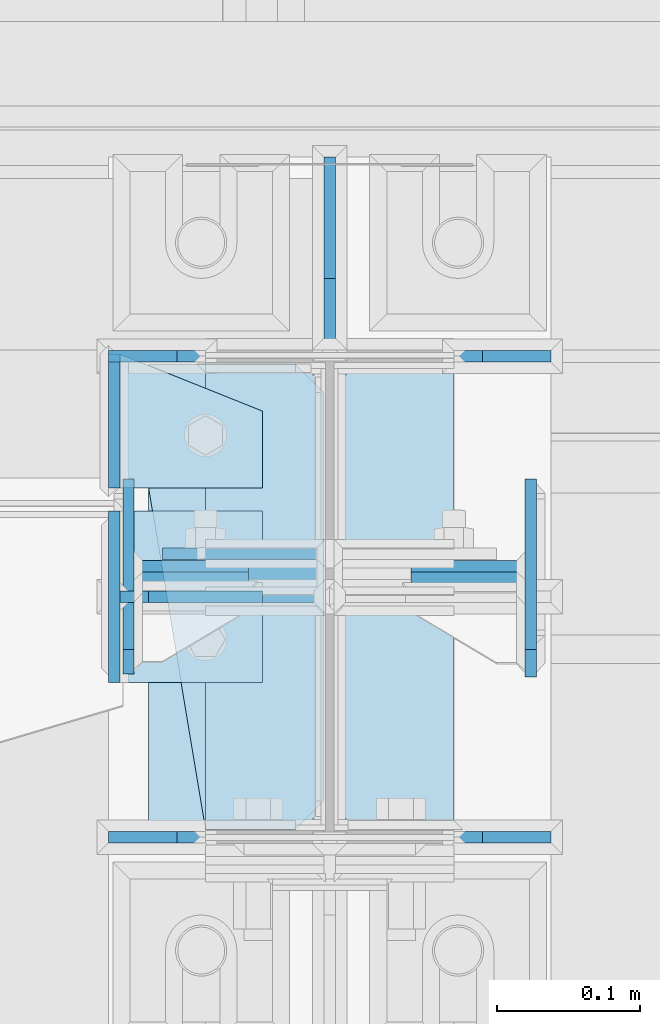
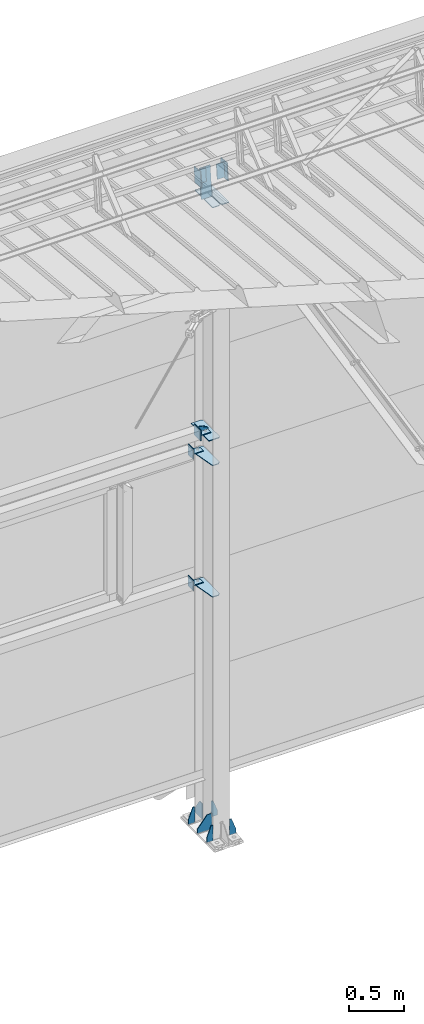
# One storey, part 165 of 709: 23 plates, 6 elements without a shape of their own.
"""IFC4 building model written with IfcOpenShell, lengths in millimetres."""

from ifc_helpers import new_model, si_unit, direction, frame, origin_with_axes, place, context, subcontext, project, spatial, line, indexed_curve, outline, extrude, material, element, aggregate, save


model = new_model("IFC4")

# Units and contexts
model_context = context("Model", 3, precision=0.2, world=origin_with_axes(), true_north=direction((0.0, 1.0)))
body_context = subcontext(model_context, "Body", "Model", "MODEL_VIEW")
ifc_project = project(units=[si_unit("LENGTHUNIT", "METRE", prefix="MILLI"), si_unit("AREAUNIT", "SQUARE_METRE"), si_unit("VOLUMEUNIT", "CUBIC_METRE"), si_unit("MASSUNIT", "GRAM", prefix="KILO"), si_unit("TIMEUNIT", "SECOND"), si_unit("PLANEANGLEUNIT", "RADIAN"), si_unit("SOLIDANGLEUNIT", "STERADIAN"), si_unit("THERMODYNAMICTEMPERATUREUNIT", "DEGREE_CELSIUS"), si_unit("LUMINOUSINTENSITYUNIT", "LUMEN")], contexts=[model_context])

# Site, building, storey
site_placement = place(None, origin_with_axes())
site = spatial("IfcSite", under=ifc_project, at=site_placement, CompositionType="ELEMENT")
building_placement = place(site_placement, origin_with_axes())
building = spatial("IfcBuilding", under=site, at=building_placement, Name="Undefined", CompositionType="ELEMENT")
storey_placement = place(building_placement, origin_with_axes())
storey = spatial("IfcBuildingStorey", under=building, at=storey_placement, Name="Undefined", CompositionType="ELEMENT", Elevation=0.0)

# Assembly, plates
assembly_1_placement = place(storey_placement, frame((46000.0, 21827.0, -200.0), z_axis=(-1.0, 0.0, 0.0), x_axis=(0.0, 0.0, 1.0)))
assembly_1 = element("IfcElementAssembly", 1, at=assembly_1_placement, inside=storey)
ifc_material = material(Name="C355-6", Category="STEEL")
plate_1_placement = place(assembly_1_placement, frame((25.0, 168.5, -87.0), z_axis=(0.0, -1.0, 0.0), x_axis=(0.0, 0.0, -1.0)))
plate_1 = element("IfcPlate", 2, at=plate_1_placement, material=ifc_material, ObjectType="419", context=body_context, shape_type="SolidModel", body=[
    extrude(outline(indexed_curve([(0.0, 0.0), (68.0, 0.0), (68.0, 50.0), (20.0, 175.0), (0.0, 175.0)], segments=[line(1, 2, 3, 4, 5, 1)])), frame((0.0, 0.0, 4.0), z_axis=(0.0, 0.0, 1.0), x_axis=(1.0, 0.0, 0.0)), (0.0, 0.0, -1.0), 8.0),
])
plate_2_placement = place(assembly_1_placement, frame((25.0, 168.5, 87.0), z_axis=(0.0, 1.0, 0.0), x_axis=(0.0, 0.0, 1.0)))
plate_2 = element("IfcPlate", 3, at=plate_2_placement, material=ifc_material, ObjectType="419", context=body_context, shape_type="SolidModel", body=[
    extrude(outline(indexed_curve([(0.0, 0.0), (68.0, 0.0), (68.0, 50.0), (20.0, 175.0), (0.0, 175.0)], segments=[line(1, 2, 3, 4, 5, 1)])), frame((0.0, 0.0, 4.0), z_axis=(0.0, 0.0, 1.0), x_axis=(1.0, 0.0, 0.0)), (0.0, 0.0, -1.0), 8.0),
])
plate_3_placement = place(assembly_1_placement, frame((25.0, -168.5, -87.0), z_axis=(0.0, -1.0, 0.0), x_axis=(0.0, 0.0, -1.0)))
plate_3 = element("IfcPlate", 4, at=plate_3_placement, material=ifc_material, ObjectType="419", context=body_context, shape_type="SolidModel", body=[
    extrude(outline(indexed_curve([(0.0, 0.0), (68.0, 0.0), (68.0, 50.0), (20.0, 175.0), (0.0, 175.0)], segments=[line(1, 2, 3, 4, 5, 1)])), frame((0.0, 0.0, 4.0), z_axis=(0.0, 0.0, 1.0), x_axis=(1.0, 0.0, 0.0)), (0.0, 0.0, -1.0), 8.0),
])
plate_4_placement = place(assembly_1_placement, frame((25.0, -168.5, 87.0), z_axis=(0.0, 1.0, 0.0), x_axis=(0.0, 0.0, 1.0)))
plate_4 = element("IfcPlate", 5, at=plate_4_placement, material=ifc_material, ObjectType="419", context=body_context, shape_type="SolidModel", body=[
    extrude(outline(indexed_curve([(0.0, 0.0), (68.0, 0.0), (68.0, 50.0), (20.0, 175.0), (0.0, 175.0)], segments=[line(1, 2, 3, 4, 5, 1)])), frame((0.0, 0.0, 4.0), z_axis=(0.0, 0.0, 1.0), x_axis=(1.0, 0.0, 0.0)), (0.0, 0.0, -1.0), 8.0),
])
plate_5_placement = place(assembly_1_placement, frame((25.0, 0.0, 3.0), z_axis=(0.0, 1.0, 0.0), x_axis=(0.0, 0.0, 1.0)))
plate_5 = element("IfcPlate", 6, at=plate_5_placement, material=ifc_material, ObjectType="417", context=body_context, shape_type="SolidModel", body=[
    extrude(outline(indexed_curve([(0.0, 0.0), (152.0, 0.0), (152.0, 50.0), (50.0, 175.0), (0.0, 175.0)], segments=[line(1, 2, 3, 4, 5, 1)])), frame((0.0, 0.0, 4.0), z_axis=(0.0, 0.0, 1.0), x_axis=(1.0, 0.0, 0.0)), (0.0, 0.0, -1.0), 8.0),
])
plate_6_placement = place(assembly_1_placement, frame((25.0, 173.0, 0.0), z_axis=(0.0, 0.0, -1.0), x_axis=(0.0, 1.0, 0.0)))
plate_6 = element("IfcPlate", 7, at=plate_6_placement, material=ifc_material, ObjectType="418", context=body_context, shape_type="SolidModel", body=[
    extrude(outline(indexed_curve([(0.0, 0.0), (135.0, 0.0), (135.0, 50.0), (50.0, 175.0), (0.0, 175.0)], segments=[line(1, 2, 3, 4, 5, 1)])), frame((0.0, 0.0, 4.0), z_axis=(0.0, 0.0, 1.0), x_axis=(1.0, 0.0, 0.0)), (0.0, 0.0, -1.0), 8.0),
])
plate_7_placement = place(assembly_1_placement, frame((7097.93718, -163.0, -87.0), z_axis=(-1.0, 0.0, 0.0), x_axis=(0.0, 0.0, 1.0)))
plate_7 = element("IfcPlate", 8, at=plate_7_placement, material=ifc_material, ObjectType="461", context=body_context, shape_type="SolidModel", body=[
    extrude(outline(indexed_curve([(0.0, 0.0), (68.0, 0.0), (83.0, 15.0), (83.0, 311.0), (68.0, 326.0), (0.0, 326.0)], segments=[line(1, 2, 3, 4, 5, 6, 1)])), frame((0.0, 0.0, 4.0), z_axis=(0.0, 0.0, 1.0), x_axis=(1.0, 0.0, 0.0)), (0.0, 0.0, -1.0), 8.0),
])
plate_8_placement = place(assembly_1_placement, frame((7097.93718, 163.0, 87.0), z_axis=(-1.0, 0.0, 0.0), x_axis=(0.0, 0.0, -1.0)))
plate_8 = element("IfcPlate", 9, at=plate_8_placement, material=ifc_material, ObjectType="461", context=body_context, shape_type="SolidModel", body=[
    extrude(outline(indexed_curve([(0.0, 0.0), (68.0, 0.0), (83.0, 15.0), (83.0, 311.0), (68.0, 326.0), (0.0, 326.0)], segments=[line(1, 2, 3, 4, 5, 6, 1)])), frame((0.0, 0.0, 4.0), z_axis=(0.0, 0.0, 1.0), x_axis=(1.0, 0.0, 0.0)), (0.0, 0.0, -1.0), 8.0),
])
plate_9_placement = place(assembly_1_placement, frame((2742.0, 163.0, 4.0), z_axis=(1.0, 0.0, 0.0), x_axis=(0.0, 0.0, 1.0)))
plate_9 = element("IfcPlate", 10, at=plate_9_placement, material=ifc_material, ObjectType="543", context=body_context, shape_type="SolidModel", body=[
    extrude(outline(indexed_curve([(0.0, 20.0), (20.0, 0.0), (123.0, 0.0), (123.0, 86.0), (83.0, 326.0), (20.0, 326.0), (0.0, 306.0)], segments=[line(1, 2, 3, 4, 5, 6, 7, 1)])), frame((0.0, 0.0, 4.0), z_axis=(0.0, 0.0, 1.0), x_axis=(1.0, 0.0, 0.0)), (0.0, 0.0, -1.0), 8.0),
])
plate_10_placement = place(assembly_1_placement, frame((4212.0, 163.0, 4.0), z_axis=(1.0, 0.0, 0.0), x_axis=(0.0, 0.0, 1.0)))
plate_10 = element("IfcPlate", 11, at=plate_10_placement, material=ifc_material, ObjectType="543", context=body_context, shape_type="SolidModel", body=[
    extrude(outline(indexed_curve([(0.0, 20.0), (20.0, 0.0), (123.0, 0.0), (123.0, 86.0), (83.0, 326.0), (20.0, 326.0), (0.0, 306.0)], segments=[line(1, 2, 3, 4, 5, 6, 7, 1)])), frame((0.0, 0.0, 4.0), z_axis=(0.0, 0.0, 1.0), x_axis=(1.0, 0.0, 0.0)), (0.0, 0.0, -1.0), 8.0),
])
plate_11_placement = place(assembly_1_placement, frame((4502.0, 163.0, 127.0), z_axis=(-1.0, 0.0, 0.0), x_axis=(0.0, 0.0, -1.0)))
plate_11 = element("IfcPlate", 12, at=plate_11_placement, material=ifc_material, ObjectType="547", context=body_context, shape_type="SolidModel", body=[
    extrude(outline(indexed_curve([(0.0, 0.0), (108.0, 0.0), (123.0, 15.0), (123.0, 311.0), (108.0, 326.0), (0.0, 326.0)], segments=[line(1, 2, 3, 4, 5, 6, 1)])), frame((0.0, 0.0, 4.0), z_axis=(0.0, 0.0, 1.0), x_axis=(1.0, 0.0, 0.0)), (0.0, 0.0, -1.0), 8.0),
])
plate_12_placement = place(assembly_1_placement, frame((7434.21546, 30.02526, 3.0), z_axis=(0.099503719, -0.9950371902, 0.0), x_axis=(0.0, 0.0, 1.0)))
plate_12 = element("IfcPlate", 13, at=plate_12_placement, material=ifc_material, ObjectType="595", context=body_context, shape_type="SolidModel", body=[
    extrude(outline(indexed_curve([(0.0, 0.0), (114.0, 0.0), (114.0, 332.53554), (0.0, 332.53554)], segments=[line(1, 2, 3, 4, 1)])), frame((0.0, 0.0, 4.0), z_axis=(0.0, 0.0, 1.0), x_axis=(1.0, 0.0, 0.0)), (0.0, 0.0, -1.0), 8.0),
])
aggregate(assembly_1, [plate_1, plate_2, plate_3, plate_4, plate_5, plate_6, plate_7, plate_8, plate_9, plate_10, plate_11, plate_12])

assembly_2_placement = place(storey_placement, frame((46000.0, 21950.0, 2550.0), z_axis=(0.0, 0.0, -1.0), x_axis=(-1.0, 0.0, 0.0)))
assembly_2 = element("IfcElementAssembly", 14, at=assembly_2_placement, inside=storey)
plate_13_placement = place(assembly_2_placement, frame((47.0, 47.0, 0.0), z_axis=(0.0, 0.0, 1.0), x_axis=(0.0, -1.0, 0.0)))
plate_13 = element("IfcPlate", 15, at=plate_13_placement, material=ifc_material, ObjectType="502", context=body_context, shape_type="SolidModel", body=[
    extrude(outline(indexed_curve([(0.0, 100.0), (40.0, 0.0), (94.0, 0.0), (94.0, 100.0), (0.0, 100.0)], segments=[line(1, 2, 3, 4, 5, 1)])), frame((0.0, 0.0, 4.0), z_axis=(0.0, 0.0, 1.0), x_axis=(1.0, 0.0, 0.0)), (0.0, 0.0, -1.0), 8.0),
])
plate_14_placement = place(assembly_2_placement, frame((151.0, 47.0, -60.0), z_axis=(-1.0, 0.0, 0.0), x_axis=(0.0, -1.0, 0.0)))
plate_14 = element("IfcPlate", 16, at=plate_14_placement, material=ifc_material, ObjectType="501", context=body_context, shape_type="SolidModel", body=[
    extrude(outline(indexed_curve([(0.0, 0.0), (94.0, 0.0), (94.0, 120.0), (0.0, 120.0)], segments=[line(1, 2, 3, 4, 1)])), frame((0.0, 0.0, 4.0), z_axis=(0.0, 0.0, 1.0), x_axis=(1.0, 0.0, 0.0)), (0.0, 0.0, -1.0), 8.0),
])
aggregate(assembly_2, [plate_13, plate_14])

assembly_3_placement = place(storey_placement, frame((46000.0, 21950.0, 4020.0), z_axis=(0.0, 0.0, -1.0), x_axis=(-1.0, 0.0, 0.0)))
assembly_3 = element("IfcElementAssembly", 17, at=assembly_3_placement, inside=storey)
plate_15_placement = place(assembly_3_placement, frame((47.0, 47.0, 0.0), z_axis=(0.0, 0.0, 1.0), x_axis=(0.0, -1.0, 0.0)))
plate_15 = element("IfcPlate", 18, at=plate_15_placement, material=ifc_material, ObjectType="502", context=body_context, shape_type="SolidModel", body=[
    extrude(outline(indexed_curve([(0.0, 100.0), (40.0, 0.0), (94.0, 0.0), (94.0, 100.0), (0.0, 100.0)], segments=[line(1, 2, 3, 4, 5, 1)])), frame((0.0, 0.0, 4.0), z_axis=(0.0, 0.0, 1.0), x_axis=(1.0, 0.0, 0.0)), (0.0, 0.0, -1.0), 8.0),
])
plate_16_placement = place(assembly_3_placement, frame((151.0, 47.0, -60.0), z_axis=(-1.0, 0.0, 0.0), x_axis=(0.0, -1.0, 0.0)))
plate_16 = element("IfcPlate", 19, at=plate_16_placement, material=ifc_material, ObjectType="501", context=body_context, shape_type="SolidModel", body=[
    extrude(outline(indexed_curve([(0.0, 0.0), (94.0, 0.0), (94.0, 120.0), (0.0, 120.0)], segments=[line(1, 2, 3, 4, 1)])), frame((0.0, 0.0, 4.0), z_axis=(0.0, 0.0, 1.0), x_axis=(1.0, 0.0, 0.0)), (0.0, 0.0, -1.0), 8.0),
])
aggregate(assembly_3, [plate_15, plate_16])

assembly_4_placement = place(storey_placement, frame((46000.0, 21827.0, 4310.0), z_axis=(0.0, 0.0, -1.0), x_axis=(-1.0, 0.0, 0.0)))
assembly_4 = element("IfcElementAssembly", 20, at=assembly_4_placement, inside=storey)
plate_17_placement = place(assembly_4_placement, frame((151.0, 60.0, 60.0), z_axis=(-1.0, 0.0, 0.0), x_axis=(0.0, 0.0, -1.0)))
plate_17 = element("IfcPlate", 21, at=plate_17_placement, material=ifc_material, ObjectType="506", context=body_context, shape_type="SolidModel", body=[
    extrude(outline(indexed_curve([(0.0, 0.0), (120.0, 0.0), (120.0, 120.0), (0.0, 120.0)], segments=[line(1, 2, 3, 4, 1)])), frame((0.0, 0.0, 4.0), z_axis=(0.0, 0.0, 1.0), x_axis=(1.0, 0.0, 0.0)), (0.0, 0.0, -1.0), 8.0),
])
plate_18_placement = place(assembly_4_placement, frame((47.0, 0.0, -60.0), z_axis=(0.0, 1.0, 0.0), x_axis=(0.0, 0.0, 1.0)))
plate_18 = element("IfcPlate", 22, at=plate_18_placement, material=ifc_material, ObjectType="508", context=body_context, shape_type="SolidModel", body=[
    extrude(outline(indexed_curve([(0.0, 80.0), (36.0, 0.0), (56.0, 0.0), (56.0, 90.0), (46.0, 100.0), (0.0, 100.0)], segments=[line(1, 2, 3, 4, 5, 6, 1)])), frame((0.0, 0.0, 4.0), z_axis=(0.0, 0.0, 1.0), x_axis=(1.0, 0.0, 0.0)), (0.0, 0.0, -1.0), 8.0),
])
plate_19_placement = place(assembly_4_placement, frame((47.0, 60.0, 0.0), z_axis=(0.0, 0.0, 1.0), x_axis=(0.0, -1.0, 0.0)))
plate_19 = element("IfcPlate", 23, at=plate_19_placement, material=ifc_material, ObjectType="507", context=body_context, shape_type="SolidModel", body=[
    extrude(outline(indexed_curve([(0.0, 0.0), (120.0, 0.0), (120.0, 100.0), (0.0, 100.0)], segments=[line(1, 2, 3, 4, 1)])), frame((0.0, 0.0, 4.0), z_axis=(0.0, 0.0, 1.0), x_axis=(1.0, 0.0, 0.0)), (0.0, 0.0, -1.0), 8.0),
])
aggregate(assembly_4, [plate_17, plate_18, plate_19])

assembly_5_placement = place(storey_placement, frame((46000.0, 21841.04467, 7154.40952), z_axis=(0.0, -0.9950371902, 0.099503719), x_axis=(-1.0, 0.0, 0.0)))
assembly_5 = element("IfcElementAssembly", 24, at=assembly_5_placement, inside=storey)
plate_20_placement = place(assembly_5_placement, frame((57.0, -72.0, 0.0), z_axis=(0.0, 0.0, 1.0), x_axis=(1.0, 0.0, 0.0)))
plate_20 = element("IfcPlate", 25, at=plate_20_placement, material=ifc_material, ObjectType="597", context=body_context, shape_type="SolidModel", body=[
    extrude(outline(indexed_curve([(0.0, 0.0), (80.0, 0.0), (80.0, 144.0), (0.0, 144.0)], segments=[line(1, 2, 3, 4, 1)])), frame((0.0, 0.0, 4.0), z_axis=(0.0, 0.0, 1.0), x_axis=(1.0, 0.0, 0.0)), (0.0, 0.0, -1.0), 8.0),
])
plate_21_placement = place(assembly_5_placement, frame((141.0, -87.0, -60.0), z_axis=(-1.0, 0.0, 0.0), x_axis=(0.0, 0.0, 1.0)))
plate_21 = element("IfcPlate", 26, at=plate_21_placement, material=ifc_material, ObjectType="596", context=body_context, shape_type="SolidModel", body=[
    extrude(outline(indexed_curve([(0.0, 0.0), (120.0, 0.0), (120.0, 174.0), (0.0, 174.0)], segments=[line(1, 2, 3, 4, 1)])), frame((0.0, 0.0, 4.0), z_axis=(0.0, 0.0, 1.0), x_axis=(1.0, 0.0, 0.0)), (0.0, 0.0, -1.0), 8.0),
])
aggregate(assembly_5, [plate_20, plate_21])

assembly_6_placement = place(storey_placement, frame((50000.0, 21840.04963, 7144.45915), z_axis=(0.0, -0.9950371902, 0.099503719), x_axis=(-1.0, 0.0, 0.0)))
assembly_6 = element("IfcElementAssembly", 27, at=assembly_6_placement, inside=storey)
plate_22_placement = place(assembly_6_placement, frame((3943.0, 82.0, 0.0), z_axis=(0.0, 0.0, 1.0), x_axis=(-1.0, 0.0, 0.0)))
plate_22 = element("IfcPlate", 28, at=plate_22_placement, material=ifc_material, ObjectType="583", context=body_context, shape_type="SolidModel", body=[
    extrude(outline(indexed_curve([(0.0, 0.0), (80.0, 0.0), (80.0, 164.0), (0.0, 164.0)], segments=[line(1, 2, 3, 4, 1)])), frame((0.0, 0.0, 4.0), z_axis=(0.0, 0.0, 1.0), x_axis=(1.0, 0.0, 0.0)), (0.0, 0.0, -1.0), 8.0),
])
plate_23_placement = place(assembly_6_placement, frame((3859.0, -97.0, 60.0), z_axis=(1.0, 0.0, 0.0), x_axis=(0.0, 0.0, -1.0)))
plate_23 = element("IfcPlate", 29, at=plate_23_placement, material=ifc_material, ObjectType="582", context=body_context, shape_type="SolidModel", body=[
    extrude(outline(indexed_curve([(0.0, 0.0), (120.0, 0.0), (120.0, 194.0), (0.0, 194.0)], segments=[line(1, 2, 3, 4, 1)])), frame((0.0, 0.0, 4.0), z_axis=(0.0, 0.0, 1.0), x_axis=(1.0, 0.0, 0.0)), (0.0, 0.0, -1.0), 8.0),
])
aggregate(assembly_6, [plate_22, plate_23])

save(model, "model.ifc")
